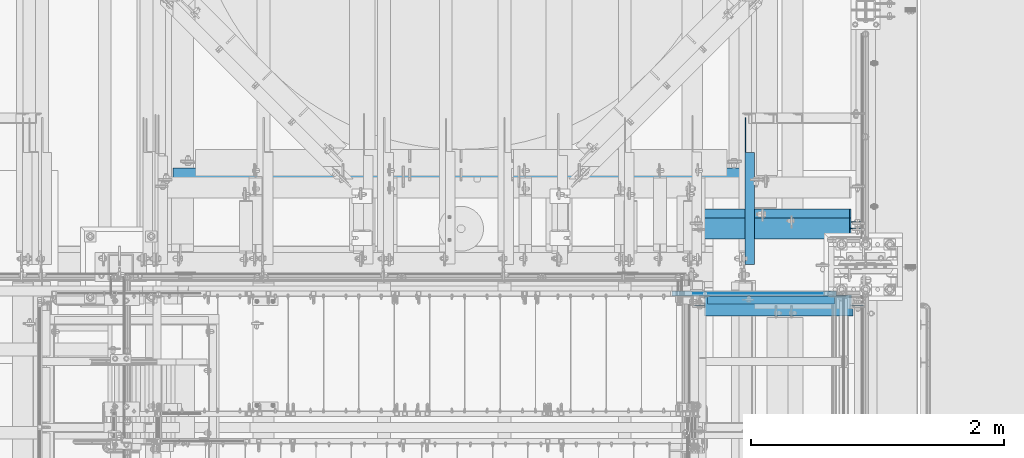
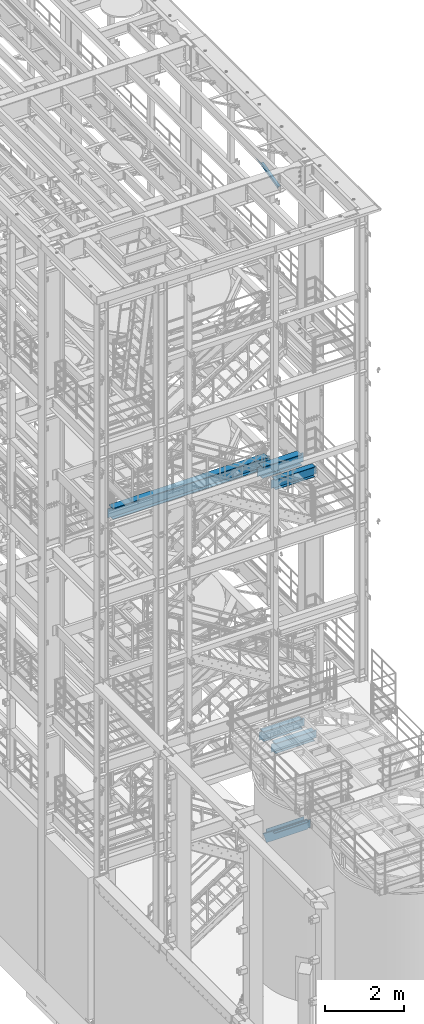
# One storey, part 996 of 1876: 9 beams, 8 elements without a shape of their own.
"""IFC2X3 building model written with IfcOpenShell, lengths in millimetres."""

import ifcopenshell
import ifcopenshell.guid

model = None  # the IFC model being written
_history = None  # IfcOwnerHistory: only IFC2X3 demands one
_inside = {}  # id of a spatial element -> (the spatial element, [elements in it])
_under = {}  # id of a project, library or spatial element -> (it, [spatial elements below it])
_declared = {}  # id of a project -> (the project, [libraries it declares])
_typed = {}  # id of a type object -> (the type object, [elements of that type])
_made_of = {}  # id of a material, layer set ... -> (it, [elements and type objects made of it])


def new_model(schema):
    """Start an empty IFC model of exactly this schema.

    Asked for "IFC4X3", IfcOpenShell would pick the latest addendum, in which some entities
    have other attributes; the version numbers below select the first issue.
    IFC2X3 requires an IfcOwnerHistory on every rooted entity: one is made here for all.
    """
    global model, _history
    if schema == "IFC4X3":
        model = ifcopenshell.file(schema_version=(4, 3, 0, 0))
    else:
        model = ifcopenshell.file(schema=schema)
    _inside.clear()
    _under.clear()
    _declared.clear()
    _typed.clear()
    _made_of.clear()
    _history = None
    if model.schema == "IFC2X3":
        org = make("IfcOrganization", Name="unknown")
        user = make(
            "IfcPersonAndOrganization",
            ThePerson=make("IfcPerson", FamilyName="unknown"),
            TheOrganization=org,
        )
        app = make(
            "IfcApplication",
            ApplicationDeveloper=org,
            Version="unknown",
            ApplicationFullName="unknown",
            ApplicationIdentifier="unknown",
        )
        _history = make(
            "IfcOwnerHistory",
            OwningUser=user,
            OwningApplication=app,
            ChangeAction="ADDED",
            CreationDate=0,
        )
    return model


def make(cls, **values):
    """One entity of the class cls with the attributes given. An attribute that is None is left unset."""
    return model.create_entity(
        cls, **{name: value for name, value in values.items() if value is not None}
    )


def rooted(cls, **values):
    """An entity with a GlobalId (a new one), such as an element, a storey or a relation."""
    return make(cls, GlobalId=ifcopenshell.guid.new(), OwnerHistory=_history, **values)


def si_unit(unit_type, name, prefix=None):
    """IfcSIUnit, for example si_unit("LENGTHUNIT", "METRE", prefix="MILLI")."""
    return make("IfcSIUnit", UnitType=unit_type, Prefix=prefix, Name=name)


def assignment(units):
    """IfcUnitAssignment: the units of a project."""
    return None if units is None else make("IfcUnitAssignment", Units=units)


def point(xyz):
    """IfcCartesianPoint."""
    return None if xyz is None else make("IfcCartesianPoint", Coordinates=xyz)


def direction(xyz):
    """IfcDirection."""
    return None if xyz is None else make("IfcDirection", DirectionRatios=xyz)


def frame(location, z_axis=None, x_axis=None):
    """IfcAxis2Placement3D, a coordinate frame: its origin and axes. An axis left out is left unset."""
    return make(
        "IfcAxis2Placement3D",
        Location=point(location),
        Axis=direction(z_axis),
        RefDirection=direction(x_axis),
    )


def origin_with_axes():
    """The frame at (0, 0, 0) with the z axis (0, 0, 1) and the x axis (1, 0, 0) written out."""
    return frame((0.0, 0.0, 0.0), z_axis=(0.0, 0.0, 1.0), x_axis=(1.0, 0.0, 0.0))


def place(relative_to, where):
    """IfcLocalPlacement: puts the frame where relative to a parent placement (None: the world)."""
    return make(
        "IfcLocalPlacement", PlacementRelTo=relative_to, RelativePlacement=where
    )


def context(
    kind, dimensions, precision=None, world=None, true_north=None, identifier=None
):
    """IfcGeometricRepresentationContext, for example the 3D "Model" context."""
    return make(
        "IfcGeometricRepresentationContext",
        ContextIdentifier=identifier,
        ContextType=kind,
        CoordinateSpaceDimension=dimensions,
        Precision=precision,
        WorldCoordinateSystem=world,
        TrueNorth=true_north,
    )


def subcontext(parent, identifier, kind, view, scale=None):
    """IfcGeometricRepresentationSubContext, for example "Body" below "Model"."""
    return make(
        "IfcGeometricRepresentationSubContext",
        ContextIdentifier=identifier,
        ContextType=kind,
        ParentContext=parent,
        TargetScale=scale,
        TargetView=view,
    )


def project(units=None, contexts=None):
    """IfcProject with its units and contexts."""
    return rooted(
        "IfcProject",
        Name="project",
        RepresentationContexts=contexts,
        UnitsInContext=assignment(units),
    )


def spatial(cls, under=None, at=None, **own):
    """A site, building, storey or space (cls), placed at a placement, below another one or the project."""
    s = rooted(cls, ObjectPlacement=at, **own)
    if under is not None:
        _under.setdefault(under.id(), (under, []))[1].append(s)
    return s


def faces_of(points, faces, orient=None, outer=None):
    """IfcFace entities. A face is a list of loops; a loop is a list of indices into points, from 0.

    orient and outer hold one flag for each loop. By default every Orientation is true, the
    first loop of a face is its IfcFaceOuterBound and the others are IfcFaceBound.
    """
    made = []
    for i, loops in enumerate(faces):
        bounds = []
        for j, loop in enumerate(loops):
            is_outer = j == 0 if outer is None else outer[i][j]
            bounds.append(
                make(
                    "IfcFaceOuterBound" if is_outer else "IfcFaceBound",
                    Bound=make("IfcPolyLoop", Polygon=[points[k] for k in loop]),
                    Orientation=True if orient is None else orient[i][j],
                )
            )
        made.append(make("IfcFace", Bounds=bounds))
    return made


def faceted_brep(points, faces, orient=None, outer=None, voids=None):
    """IfcFacetedBrep: a solid bounded by flat faces; with voids (closed shells), ...WithVoids."""
    shared = [point(p) for p in points]
    hull = make("IfcClosedShell", CfsFaces=faces_of(shared, faces, orient, outer))
    if voids is None:
        return make("IfcFacetedBrep", Outer=hull)
    return make(
        "IfcFacetedBrepWithVoids",
        Outer=hull,
        Voids=[
            make(cls, CfsFaces=faces_of(shared, fs, o, b)) for cls, fs, o, b in voids
        ],
    )


def shape(context_of_items, identifier, shape_type, items):
    """IfcShapeRepresentation: the items that make up one representation, for example the "Body"."""
    return make(
        "IfcShapeRepresentation",
        ContextOfItems=context_of_items,
        RepresentationIdentifier=identifier,
        RepresentationType=shape_type,
        Items=items,
    )


def material(Name=None, Category=None):
    """IfcMaterial."""
    return make("IfcMaterial", Name=Name, Category=Category)


def made_of(thing, what):
    """Note that an element or type object is made of a material, layer set ...; save() writes the relation."""
    if what is not None:
        _made_of.setdefault(what.id(), (what, []))[1].append(thing)
    return thing


def type_object(cls, material=None, **own):
    """A type object (cls), such as IfcWallType, which elements share."""
    return made_of(rooted(cls, **own), material)


def element(
    cls,
    number,
    at=None,
    inside=None,
    cuts=None,
    type_object=None,
    material=None,
    context=None,
    identifier="Body",
    shape_type=None,
    held_by="IfcProductDefinitionShape",
    body=None,
    shapes=None,
    **own,
):
    """One element of the class cls, such as IfcWall. Its Tag is "e" and its number.

    at: its placement. inside: the storey or other place that contains it. cuts: it is an
    opening in that element (IfcRelVoidsElement). A single representation is given by context,
    identifier, shape_type and body (its items); several are given by shapes. held_by: the class
    of the entity that holds the representations. save() writes the other relations.
    """
    e = rooted(cls, Tag="e%d" % number, ObjectPlacement=at, **own)
    if body is not None:
        shapes = [shape(context, identifier, shape_type, body)]
    if shapes is not None:
        e.Representation = make(held_by, Representations=shapes)
    if inside is not None:
        _inside.setdefault(inside.id(), (inside, []))[1].append(e)
    if cuts is not None:
        rooted(
            "IfcRelVoidsElement", RelatingBuildingElement=cuts, RelatedOpeningElement=e
        )
    if type_object is not None:
        _typed.setdefault(type_object.id(), (type_object, []))[1].append(e)
    return made_of(e, material)


def aggregate(whole, parts):
    """IfcRelAggregates: a whole, such as a stair, and the parts it consists of."""
    return rooted("IfcRelAggregates", RelatingObject=whole, RelatedObjects=parts)


def save(model, path):
    """Write the relations noted so far, then the file.

    IfcRelAggregates (storeys below a building ...), IfcRelContainedInSpatialStructure (elements
    in a storey), IfcRelDefinesByType, IfcRelAssociatesMaterial and IfcRelDeclares: one each for
    every whole, place, type object, material and project.
    """
    for whole, parts in _under.values():
        aggregate(whole, parts)
    for where, things in _inside.values():
        rooted(
            "IfcRelContainedInSpatialStructure",
            RelatedElements=things,
            RelatingStructure=where,
        )
    for kind, things in _typed.values():
        rooted("IfcRelDefinesByType", RelatedObjects=things, RelatingType=kind)
    for what, things in _made_of.values():
        rooted("IfcRelAssociatesMaterial", RelatedObjects=things, RelatingMaterial=what)
    for by, libraries in _declared.values():
        rooted("IfcRelDeclares", RelatingContext=by, RelatedDefinitions=libraries)
    model.write(path)


model = new_model("IFC2X3")

# Units and contexts
model_context = context("Model", 3, precision=1e-05, world=origin_with_axes())
body_context = subcontext(model_context, "Body", "Model", "MODEL_VIEW")
ifc_project = project(units=[si_unit("LENGTHUNIT", "METRE", prefix="MILLI"), si_unit("AREAUNIT", "SQUARE_METRE"), si_unit("VOLUMEUNIT", "CUBIC_METRE"), si_unit("MASSUNIT", "GRAM", prefix="KILO"), si_unit("TIMEUNIT", "SECOND"), si_unit("PLANEANGLEUNIT", "RADIAN"), si_unit("SOLIDANGLEUNIT", "STERADIAN"), si_unit("THERMODYNAMICTEMPERATUREUNIT", "DEGREE_CELSIUS"), si_unit("LUMINOUSINTENSITYUNIT", "LUMEN")], contexts=[model_context])

# Site, building, storey
site_placement = place(None, origin_with_axes())
site = spatial("IfcSite", under=ifc_project, at=site_placement, CompositionType="ELEMENT")
building_placement = place(site_placement, origin_with_axes())
building = spatial("IfcBuilding", under=site, at=building_placement, Name="Undefined", CompositionType="ELEMENT")
storey_placement = place(building_placement, origin_with_axes())
storey = spatial("IfcBuildingStorey", under=building, at=storey_placement, Name="Undefined", CompositionType="ELEMENT", Elevation=0.0)

# Assembly, beam
assembly_1_placement = place(storey_placement, origin_with_axes())
assembly_1 = element("IfcElementAssembly", 1, at=assembly_1_placement, inside=storey, Name="STRINGER", AssemblyPlace="NOTDEFINED", PredefinedType="RIGID_FRAME")
ifc_material_1 = material(Name="STEEL/A36")
beam_type_1 = type_object("IfcBeamType", Name="L2-1/2X2-1/2X1/4", PredefinedType="NOTDEFINED")
beam_1_placement = place(assembly_1_placement, frame((6284.91249266997, -4832.34999887347, 2266.27941810345), z_axis=(0.0, -1.0, 0.0), x_axis=(1.0, 0.0, 0.0)))
beam_1 = element("IfcBeam", 2, at=beam_1_placement, type_object=beam_type_1, material=ifc_material_1, Name="ANGLE", ObjectType="L2-1/2X2-1/2X1/4", context=body_context, shape_type="Brep", body=[
    faceted_brep([(82.5500000000022, 19.0499999999556, -25.3999999999996), (82.5500000000022, 19.0499996253002, -31.75), (107.950000724835, 19.0499996252966, -31.75), (107.950000724835, 19.049999999952, -25.3999999999996), (107.950000724835, -31.7499992371049, -25.3999999999996), (107.950000724835, -31.75, -31.75), (82.5500000000022, 25.3999999999996, 31.75), (82.5500000000022, 25.3999999999996, -25.3999999999996), (1090.61250039314, 25.4000000000001, -25.3999999996768), (1090.61250039313, 25.4000000000001, 31.7500000003247), (82.5500000000022, 31.75, 31.75), (1090.61250039313, 31.75, 31.7500000003247), (82.5500000000022, 31.75, -31.75), (1090.61250039314, 31.75, -31.7499999996771), (1090.61250039314, -31.75, -25.3999999996768), (1090.61250039314, -31.75, -31.7499999996771)], [[[0, 1, 2, 3]], [[4, 3, 2, 5]], [[6, 7, 8, 9]], [[10, 6, 9, 11]], [[12, 10, 11, 13]], [[9, 8, 14, 15, 13, 11]], [[15, 14, 4, 5]], [[1, 12, 13, 15, 5, 2]], [[7, 6, 10, 12, 1, 0]], [[14, 8, 7, 0, 3, 4]]]),
])

assembly_2_placement = place(storey_placement, origin_with_axes())
assembly_2 = element("IfcElementAssembly", 3, at=assembly_2_placement, inside=storey, Name="RAIL", AssemblyPlace="NOTDEFINED", PredefinedType="RIGID_FRAME")
beam_type_2 = type_object("IfcBeamType", PredefinedType="NOTDEFINED")
beam_2_placement = place(assembly_2_placement, frame((6185.29687392229, -4781.55000191054, 2393.1836258416), z_axis=(0.0, 0.0, 1.0), x_axis=(1.0, 0.0, 0.0)))
beam_2 = element("IfcBeam", 4, at=beam_2_placement, type_object=beam_type_2, material=ifc_material_1, Name="PLATE", context=body_context, shape_type="Brep", body=[
    faceted_brep([(0.0, 3.17500000000018, -50.8000000000002), (0.0, 3.17500000000018, 50.8000000000002), (1102.91562696768, 3.17500000000018, 50.8000000000466), (1102.91562696769, 3.17500000000018, -50.7999999999533), (0.0, -3.17500000000018, 50.8000000000002), (1102.91562696768, -3.17500000000018, 50.8000000000466), (0.0, -3.17500000000018, -50.8000000000002), (1102.91562696769, -3.17500000000018, -50.7999999999533)], [[[0, 1, 2, 3]], [[1, 4, 5, 2]], [[4, 6, 7, 5]], [[6, 0, 3, 7]], [[5, 7, 3, 2]], [[6, 4, 1, 0]]]),
])
aggregate(assembly_2, [beam_2])

assembly_3_placement = place(storey_placement, origin_with_axes())
assembly_3 = element("IfcElementAssembly", 5, at=assembly_3_placement, inside=storey, AssemblyPlace="NOTDEFINED", PredefinedType="RIGID_FRAME")
beam_type_3 = type_object("IfcBeamType", Name="L3X3X3/8", PredefinedType="NOTDEFINED")
beam_3_placement = place(assembly_3_placement, frame((6702.42500019074, -4562.78281844778, 21997.5317219592), z_axis=(1.0, 0.0, 0.0), x_axis=(0.0, 0.97029600569138, 0.241920774923019)))
beam_3 = element("IfcBeam", 6, at=beam_3_placement, type_object=beam_type_3, material=ifc_material_1, ObjectType="L3X3X3/8", context=body_context, shape_type="Brep", body=[
    faceted_brep([(20.4512332895073, 38.1000000000495, -38.0999999999999), (20.4512332895073, 38.1000000000495, 38.0999999999999), (892.440924395522, 38.0999999997366, 38.0999999999999), (892.440924395522, 38.0999999997366, -38.0999999999999), (20.4512332895037, 28.5750000000371, 38.0999999999999), (930.643800759319, 28.5749999997061, 38.0999999999999), (20.4512332895037, 28.5750000000371, -28.575), (930.643800759319, 28.5749999997061, -28.575), (20.4512332894728, -38.1000000000604, -28.575), (1198.0639353059, -38.1000000004824, -28.575), (20.4512332894728, -38.1000000000604, -38.0999999999999), (1198.0639353059, -38.1000000004824, -38.0999999999999)], [[[0, 1, 2, 3]], [[1, 4, 5, 2]], [[4, 6, 7, 5]], [[6, 8, 9, 7]], [[8, 10, 11, 9]], [[10, 0, 3, 11]], [[5, 7, 9, 11, 3, 2]], [[10, 8, 6, 4, 1, 0]]]),
])
aggregate(assembly_3, [beam_3])

# Beam
beam_type_4 = type_object("IfcBeamType", Name="MC12X10.6", PredefinedType="NOTDEFINED")
beam_4_placement = place(assembly_1_placement, frame((7485.06250068596, -4781.55000121439, 2177.28362013292), z_axis=(0.0, 0.0, 1.0), x_axis=(-1.0, 0.0, 0.0)))
beam_4 = element("IfcBeam", 7, at=beam_4_placement, type_object=beam_type_4, material=ifc_material_1, Name="STRINGER", ObjectType="MC12X10.6", context=body_context, shape_type="Brep", body=[
    faceted_brep([(20.6375006859598, 14.2875000000004, -127.0), (20.6375006859598, 19.0500000000002, -127.0), (84.1375008766954, 19.0500000000002, -127.0), (84.1375008766954, 14.2875000000004, -127.0), (88.9975803947409, 19.0500000000002, -127.966729922588), (88.9975803947409, 14.2875000000004, -127.966729922588), (93.1177568628946, 19.0500000000002, -130.719743823066), (93.1177568628946, 14.2875000000004, -130.719743823066), (95.870770763373, 19.0500000000002, -134.83992029122), (95.870770763373, 14.2875000000004, -134.83992029122), (96.8375006859605, 14.2875000000004, -139.699999809265), (96.8375006859605, 19.0500000000002, -139.699999809265), (96.8375006859605, 19.0500000000002, -152.4), (96.8375006859605, -19.0500000000002, -152.4), (96.8375006859605, -19.0500000000002, -144.841595), (96.8375006859605, 14.2875000000004, -144.17817875), (1394.24448031702, -19.0500000000002, 144.841595), (1396.43977205058, -19.0500000000002, 152.4), (96.8375006859605, -19.0500000000002, 152.4), (96.8375006859605, -19.0500000000002, 144.841595), (1396.43977205058, 19.0500000000002, 152.4), (96.8375006859605, 19.0500000000002, 152.4), (84.1375008766954, 14.2875000000004, 127.0), (84.1375008766954, 19.0500000000002, 127.0), (20.6375006859598, 19.0500000000002, 127.0), (20.6375006859598, 14.2875000000004, 127.0), (88.9975803947409, 14.2875000000004, 127.966729922588), (88.9975803947409, 19.0500000000002, 127.966729922588), (93.1177568628946, 14.2875000000004, 130.719743823066), (93.1177568628946, 19.0500000000002, 130.719743823066), (95.870770763373, 14.2875000000004, 134.83992029122), (95.870770763373, 19.0500000000002, 134.83992029122), (96.8375006859605, 14.2875000000004, 139.699999809265), (96.8375006859605, 19.0500000000002, 139.699999809265), (96.8375006859605, 14.2875000000004, 144.17817875), (1394.05179519237, 14.2875000000004, 144.17817875), (1310.30048417633, 14.2875000000004, -144.17817875), (1310.10779905169, -19.0500000000002, -144.841595), (1307.91250731813, -19.0500000000002, -152.4), (1307.91250731813, 19.0500000000002, -152.4)], [[[0, 1, 2, 3]], [[3, 2, 4, 5]], [[5, 4, 6, 7]], [[7, 6, 8, 9]], [[10, 11, 12, 13, 14, 15]], [[9, 8, 11, 10]], [[16, 17, 18, 19]], [[17, 20, 21, 18]], [[22, 23, 24, 25]], [[26, 27, 23, 22]], [[28, 29, 27, 26]], [[30, 31, 29, 28]], [[32, 33, 31, 30]], [[18, 21, 33, 32, 34, 19]], [[35, 16, 19, 34]], [[17, 16, 35, 36, 37, 38, 39, 20]], [[37, 36, 15, 14]], [[38, 37, 14, 13]], [[39, 38, 13, 12]], [[6, 4, 2, 1, 24, 23, 27, 29, 31, 33, 21, 20, 39, 12, 11, 8]], [[25, 24, 1, 0]], [[36, 35, 34, 32, 30, 28, 26, 22, 25, 0, 3, 5, 7, 9, 10, 15]]]),
])

aggregate(assembly_1, [beam_4, beam_1])

# Assembly, beam
assembly_4_placement = place(storey_placement, origin_with_axes())
assembly_4 = element("IfcElementAssembly", 8, at=assembly_4_placement, inside=storey, Name="BEAM", AssemblyPlace="NOTDEFINED", PredefinedType="RIGID_FRAME")
ifc_material_2 = material(Name="STEEL/A992")
beam_type_5 = type_object("IfcBeamType", Name="W12X30", PredefinedType="NOTDEFINED")
beam_5_placement = place(assembly_4_placement, frame((6233.31875, -4876.403125, 13152.4375), z_axis=(0.0, 0.0, 1.0), x_axis=(1.0, 0.0, 0.0)))
beam_5 = element("IfcBeam", 9, at=beam_5_placement, type_object=beam_type_5, material=ifc_material_2, Name="BEAM", ObjectType="W12X30", context=body_context, shape_type="Brep", body=[
    faceted_brep([(1273.96875, -3.17500000000018, -146.049999999999), (1273.96875, -82.5500000000002, -146.049999999999), (1273.96875, -82.5500000000002, -157.1625), (1273.96875, 82.5500000000002, -157.1625), (1273.96875, 82.5500000000002, -146.049999999999), (1273.96875, 3.17500000000018, -146.049999999999), (1273.96875, 3.17500000000018, -138.112499809266), (1273.96875, -3.17500000000018, -138.112499809266), (1274.93547992258, 3.17500000000018, -133.252420291219), (1274.93547992258, -3.17500000000018, -133.252420291219), (1277.68849382306, 3.17500000000018, -129.132243823065), (1277.68849382306, -3.17500000000018, -129.132243823065), (1281.80867029122, 3.17500000000018, -126.379229922588), (1281.80867029122, -3.17500000000018, -126.379229922588), (1286.66874980926, 3.17500000000018, -125.4125), (1286.66874980926, -3.17500000000018, -125.4125), (1369.21875, -3.17500000000018, -125.4125), (1369.21875, 3.17500000000018, -125.4125), (113.506249999999, 3.17500000000018, 146.049999999999), (113.506249999999, 82.5500000000002, 146.049999999999), (1286.66875, 82.5500000000002, 146.049999999999), (1286.66875, 3.17500000000018, 146.049999999999), (126.206249999999, -3.17500000000018, -144.462499809266), (126.206249999999, 3.17500000000018, -144.462499809266), (126.206249999999, 3.17500000000018, -146.049999999999), (126.206249999999, 82.5500000000002, -146.049999999999), (126.206249999999, 82.5500000000002, -157.1625), (126.206249999999, -82.5500000000002, -157.1625), (126.206249999999, -82.5500000000002, -146.049999999999), (126.206249999999, -3.17500000000018, -146.049999999999), (125.239520077412, -3.17500000000018, -139.602420291219), (125.239520077412, 3.17500000000018, -139.602420291219), (122.486506176933, -3.17500000000018, -135.482243823066), (122.486506176933, 3.17500000000018, -135.482243823066), (118.36632970878, -3.17500000000018, -132.729229922588), (118.36632970878, 3.17500000000018, -132.729229922588), (113.506250190734, -3.17500000000018, -131.762500000001), (113.506250190734, 3.17500000000018, -131.762500000001), (30.9562499999993, -3.17500000000018, -131.762500000001), (30.9562499999993, 3.17500000000018, -131.762500000001), (30.9562499999993, -3.17500000000018, 131.762500000001), (30.9562499999993, 3.17500000000018, 131.762500000001), (100.806250190734, -3.17500000000018, 131.762500000001), (100.806250190734, 3.17500000000018, 131.762500000001), (105.66632970878, -3.17500000000018, 132.729229922588), (105.66632970878, 3.17500000000018, 132.729229922588), (109.786506176933, -3.17500000000018, 135.482243823066), (109.786506176933, 3.17500000000018, 135.482243823066), (112.539520077412, -3.17500000000018, 139.602420291219), (112.539520077412, 3.17500000000018, 139.602420291219), (113.506249999999, -3.17500000000018, 144.462499809266), (113.506249999999, 3.17500000000018, 144.462499809266), (113.506249999999, -82.5500000000002, 157.1625), (113.506249999999, 82.5500000000002, 157.1625), (113.506249999999, -3.17500000000018, 146.049999999999), (113.506249999999, -82.5500000000002, 146.049999999999), (1286.66875, -3.17500000000018, 146.049999999999), (1286.66875, -82.5500000000002, 146.049999999999), (1286.66875, -82.5500000000002, 157.1625), (1286.66875, 82.5500000000002, 157.1625), (1286.66875, -3.17500000000018, 138.112499809266), (1286.66875, 3.17500000000018, 138.112499809266), (1287.63547992258, -3.17500000000018, 133.252420291219), (1287.63547992258, 3.17500000000018, 133.252420291219), (1290.38849382306, -3.17500000000018, 129.132243823065), (1290.38849382306, 3.17500000000018, 129.132243823065), (1294.50867029122, -3.17500000000018, 126.379229922588), (1294.50867029122, 3.17500000000018, 126.379229922588), (1299.36874980926, -3.17500000000018, 125.4125), (1299.36874980926, 3.17500000000018, 125.4125), (1369.21875, -3.17500000000018, 125.4125), (1369.21875, 3.17500000000018, 125.4125)], [[[0, 1, 2, 3, 4, 5, 6, 7]], [[7, 6, 8, 9]], [[9, 8, 10, 11]], [[11, 10, 12, 13]], [[13, 12, 14, 15]], [[16, 15, 14, 17]], [[18, 19, 20, 21]], [[22, 23, 24, 25, 26, 27, 28, 29]], [[30, 31, 23, 22]], [[32, 33, 31, 30]], [[34, 35, 33, 32]], [[36, 37, 35, 34]], [[38, 39, 37, 36]], [[40, 41, 39, 38]], [[42, 43, 41, 40]], [[44, 45, 43, 42]], [[46, 47, 45, 44]], [[48, 49, 47, 46]], [[50, 51, 49, 48]], [[52, 53, 19, 18, 51, 50, 54, 55]], [[55, 54, 56, 57]], [[52, 55, 57, 58]], [[53, 52, 58, 59]], [[19, 53, 59, 20]], [[58, 57, 56, 60, 61, 21, 20, 59]], [[62, 63, 61, 60]], [[64, 65, 63, 62]], [[66, 67, 65, 64]], [[68, 69, 67, 66]], [[70, 71, 69, 68]], [[71, 70, 16, 17]], [[12, 10, 8, 6, 5, 24, 23, 31, 33, 35, 37, 39, 41, 43, 45, 47, 49, 51, 18, 21, 61, 63, 65, 67, 69, 71, 17, 14]], [[25, 24, 5, 4]], [[26, 25, 4, 3]], [[27, 26, 3, 2]], [[28, 27, 2, 1]], [[29, 28, 1, 0]], [[70, 68, 66, 64, 62, 60, 56, 54, 50, 48, 46, 44, 42, 40, 38, 36, 34, 32, 30, 22, 29, 0, 7, 9, 11, 13, 15, 16]]]),
])
aggregate(assembly_4, [beam_5])

assembly_5_placement = place(storey_placement, origin_with_axes())
assembly_5 = element("IfcElementAssembly", 10, at=assembly_5_placement, inside=storey, Name="BEAM", AssemblyPlace="NOTDEFINED", PredefinedType="RIGID_FRAME")
beam_6_placement = place(assembly_5_placement, frame((6248.4, -4876.8, 4973.6375), z_axis=(0.0, 0.0, 1.0), x_axis=(1.0, 0.0, 0.0)))
beam_6 = element("IfcBeam", 11, at=beam_6_placement, type_object=beam_type_5, material=ifc_material_2, Name="BEAM", ObjectType="W12X30", context=body_context, shape_type="Brep", body=[
    faceted_brep([(15.875, -3.17500000000018, -131.762499999999), (15.875, 3.17500000000018, -131.762499999999), (98.4250001907349, 3.17500000000018, -131.762499999999), (98.4250001907349, -3.17500000000018, -131.762499999999), (103.28507970878, 3.17500000000018, -132.729229922586), (103.28507970878, -3.17500000000018, -132.729229922586), (107.405256176934, 3.17500000000018, -135.482243823065), (107.405256176934, -3.17500000000018, -135.482243823065), (110.158270077412, 3.17500000000018, -139.602420291219), (110.158270077412, -3.17500000000018, -139.602420291219), (111.125, -3.17500000000018, -144.462499809264), (111.125, 3.17500000000018, -144.462499809264), (111.124999999998, 3.17500000000018, -146.049999999999), (111.125, 82.5500000000002, -146.05), (111.125, 82.5500000000002, -157.1625), (111.125, -82.5500000000002, -157.1625), (111.125, -82.5500000000002, -146.05), (111.124999999998, -3.17500000000018, -146.049999999999), (1246.1875, 82.5500000000002, 146.05), (1246.1875, 3.17500000000018, 146.05), (95.2499999999982, 3.17500000000018, 146.049999999999), (95.25, 82.5500000000002, 146.05), (82.5500001907349, -3.17500000000018, 131.762500000001), (82.5500001907349, 3.17500000000018, 131.762500000001), (15.875, 3.17500000000018, 131.762500000001), (15.875, -3.17500000000018, 131.762500000001), (87.4100797087804, -3.17500000000018, 132.729229922588), (87.4100797087804, 3.17500000000018, 132.729229922588), (91.530256176934, -3.17500000000018, 135.482243823067), (91.530256176934, 3.17500000000018, 135.482243823067), (94.2832700774125, -3.17500000000018, 139.60242029122), (94.2832700774125, 3.17500000000018, 139.60242029122), (95.25, -3.17500000000018, 144.462499809266), (95.25, 3.17500000000018, 144.462499809266), (1246.1875, -82.5500000000002, 157.1625), (1246.1875, 82.5500000000002, 157.1625), (95.25, 82.5500000000002, 157.1625), (95.25, -82.5500000000002, 157.1625), (1246.1875, -82.5500000000002, 146.05), (95.25, -82.5500000000002, 146.05), (1246.1875, -3.17500000000018, 146.05), (95.2499999999982, -3.17500000000018, 146.049999999999), (1246.1875, -3.17500000000018, 131.762499809266), (1246.1875, 3.17500000000018, 131.762499809266), (1247.15422992259, -3.17500000000018, 126.902420291221), (1247.15422992259, 3.17500000000018, 126.902420291221), (1249.90724382307, -3.17500000000018, 122.782243823067), (1249.90724382307, 3.17500000000018, 122.782243823067), (1254.02742029122, -3.17500000000018, 120.029229922588), (1254.02742029122, 3.17500000000018, 120.029229922588), (1258.88749980927, -3.17500000000018, 119.062500000001), (1258.88749980927, 3.17500000000018, 119.062500000001), (1354.1375, -3.17500000000018, 119.062500000001), (1354.1375, 3.17500000000018, 119.062500000001), (1354.1375, -3.17500000000018, -131.762499999999), (1354.1375, 3.17500000000018, -131.762499999999), (1271.58749980926, -3.17500000000018, -131.762499999999), (1271.58749980926, 3.17500000000018, -131.762499999999), (1266.72742029122, -3.17500000000018, -132.729229922586), (1266.72742029122, 3.17500000000018, -132.729229922586), (1262.60724382307, -3.17500000000018, -135.482243823065), (1262.60724382307, 3.17500000000018, -135.482243823065), (1259.85422992259, -3.17500000000018, -139.602420291219), (1259.85422992259, 3.17500000000018, -139.602420291219), (1258.8875, -3.17500000000018, -144.462499809264), (1258.8875, 3.17500000000018, -144.462499809264), (1258.8875, -3.17500000000018, -146.05), (1258.8875, -82.5500000000002, -146.05), (1258.8875, -82.5500000000002, -157.1625), (1258.8875, 82.5500000000002, -157.1625), (1258.8875, 82.5500000000002, -146.05), (1258.8875, 3.17500000000018, -146.05)], [[[0, 1, 2, 3]], [[3, 2, 4, 5]], [[5, 4, 6, 7]], [[7, 6, 8, 9]], [[10, 11, 12, 13, 14, 15, 16, 17]], [[9, 8, 11, 10]], [[18, 19, 20, 21]], [[22, 23, 24, 25]], [[26, 27, 23, 22]], [[28, 29, 27, 26]], [[30, 31, 29, 28]], [[32, 33, 31, 30]], [[34, 35, 36, 37]], [[38, 34, 37, 39]], [[40, 38, 39, 41]], [[37, 36, 21, 20, 33, 32, 41, 39]], [[35, 18, 21, 36]], [[34, 38, 40, 42, 43, 19, 18, 35]], [[44, 45, 43, 42]], [[46, 47, 45, 44]], [[48, 49, 47, 46]], [[50, 51, 49, 48]], [[52, 53, 51, 50]], [[53, 52, 54, 55]], [[54, 56, 57, 55]], [[58, 59, 57, 56]], [[60, 61, 59, 58]], [[62, 63, 61, 60]], [[64, 65, 63, 62]], [[66, 67, 68, 69, 70, 71, 65, 64]], [[67, 66, 17, 16]], [[68, 67, 16, 15]], [[69, 68, 15, 14]], [[70, 69, 14, 13]], [[71, 70, 13, 12]], [[6, 4, 2, 1, 24, 23, 27, 29, 31, 33, 20, 19, 43, 45, 47, 49, 51, 53, 55, 57, 59, 61, 63, 65, 71, 12, 11, 8]], [[25, 24, 1, 0]], [[66, 64, 62, 60, 58, 56, 54, 52, 50, 48, 46, 44, 42, 40, 41, 32, 30, 28, 26, 22, 25, 0, 3, 5, 7, 9, 10, 17]]]),
])
aggregate(assembly_5, [beam_6])

assembly_6_placement = place(storey_placement, origin_with_axes())
assembly_6 = element("IfcElementAssembly", 12, at=assembly_6_placement, inside=storey, Name="BEAM", AssemblyPlace="NOTDEFINED", PredefinedType="RIGID_FRAME")
beam_7_placement = place(assembly_6_placement, frame((6248.4, -4267.2, 4973.6375), z_axis=(0.0, 0.0, 1.0), x_axis=(1.0, 0.0, 0.0)))
beam_7 = element("IfcBeam", 13, at=beam_7_placement, type_object=beam_type_5, material=ifc_material_2, Name="BEAM", ObjectType="W12X30", context=body_context, shape_type="Brep", body=[
    faceted_brep([(1256.50625, -3.17500000000018, -146.05), (1256.50625, -82.5500000000002, -146.05), (1256.50625, -82.5500000000002, -157.1625), (1256.50625, 82.5500000000002, -157.1625), (1256.50625, 82.5500000000002, -146.05), (1256.50625, 3.17500000000018, -146.05), (1256.50625, 3.17500000000018, -144.462499809266), (1256.50625, -3.17500000000018, -144.462499809266), (1257.47297992259, 3.17500000000018, -139.60242029122), (1257.47297992259, -3.17500000000018, -139.60242029122), (1260.22599382307, 3.17500000000018, -135.482243823067), (1260.22599382307, -3.17500000000018, -135.482243823067), (1264.34617029122, 3.17500000000018, -132.729229922588), (1264.34617029122, -3.17500000000018, -132.729229922588), (1269.20624980926, 3.17500000000018, -131.762500000001), (1269.20624980926, -3.17500000000018, -131.762500000001), (1351.75625, -3.17500000000018, -131.762500000001), (1351.75625, 3.17500000000018, -131.762500000001), (95.2499999999982, 3.17500000000018, 146.049999999999), (95.25, 82.5500000000002, 146.05), (1243.80625, 82.5500000000002, 146.05), (1243.80625, 3.17500000000018, 146.05), (111.125, -3.17500000000018, -144.462499809264), (111.125, 3.17500000000018, -144.462499809264), (111.124999999998, 3.17500000000018, -146.049999999999), (111.125, 82.5500000000002, -146.05), (111.125, 82.5500000000002, -157.1625), (111.125, -82.5500000000002, -157.1625), (111.125, -82.5500000000002, -146.05), (111.124999999998, -3.17500000000018, -146.049999999999), (110.158270077412, -3.17500000000018, -139.602420291219), (110.158270077412, 3.17500000000018, -139.602420291219), (107.405256176934, -3.17500000000018, -135.482243823065), (107.405256176934, 3.17500000000018, -135.482243823065), (103.28507970878, -3.17500000000018, -132.729229922586), (103.28507970878, 3.17500000000018, -132.729229922586), (98.4250001907349, -3.17500000000018, -131.762499999999), (98.4250001907349, 3.17500000000018, -131.762499999999), (15.875, -3.17500000000018, -131.762499999999), (15.875, 3.17500000000018, -131.762499999999), (15.875, -3.17500000000018, 131.762500000001), (15.875, 3.17500000000018, 131.762500000001), (82.5500001907349, -3.17500000000018, 131.762500000001), (82.5500001907349, 3.17500000000018, 131.762500000001), (87.4100797087804, -3.17500000000018, 132.729229922588), (87.4100797087804, 3.17500000000018, 132.729229922588), (91.530256176934, -3.17500000000018, 135.482243823067), (91.530256176934, 3.17500000000018, 135.482243823067), (94.2832700774125, -3.17500000000018, 139.60242029122), (94.2832700774125, 3.17500000000018, 139.60242029122), (95.25, -3.17500000000018, 144.462499809266), (95.25, 3.17500000000018, 144.462499809266), (95.25, -82.5500000000002, 157.1625), (95.25, 82.5500000000002, 157.1625), (95.2499999999982, -3.17500000000018, 146.049999999999), (95.25, -82.5500000000002, 146.05), (1243.80625, -3.17500000000018, 146.05), (1243.80625, -82.5500000000002, 146.05), (1243.80625, -82.5500000000002, 157.1625), (1243.80625, 82.5500000000002, 157.1625), (1243.80625, -3.17500000000018, 131.762499809264), (1243.80625, 3.17500000000018, 131.762499809264), (1244.77297992259, -3.17500000000018, 126.902420291219), (1244.77297992259, 3.17500000000018, 126.902420291219), (1247.52599382307, -3.17500000000018, 122.782243823065), (1247.52599382307, 3.17500000000018, 122.782243823065), (1251.64617029122, -3.17500000000018, 120.029229922587), (1251.64617029122, 3.17500000000018, 120.029229922587), (1256.50624980926, -3.17500000000018, 119.062499999999), (1256.50624980926, 3.17500000000018, 119.062499999999), (1351.75625, -3.17500000000018, 119.062499999999), (1351.75625, 3.17500000000018, 119.062499999999)], [[[0, 1, 2, 3, 4, 5, 6, 7]], [[7, 6, 8, 9]], [[9, 8, 10, 11]], [[11, 10, 12, 13]], [[13, 12, 14, 15]], [[16, 15, 14, 17]], [[18, 19, 20, 21]], [[22, 23, 24, 25, 26, 27, 28, 29]], [[30, 31, 23, 22]], [[32, 33, 31, 30]], [[34, 35, 33, 32]], [[36, 37, 35, 34]], [[38, 39, 37, 36]], [[40, 41, 39, 38]], [[42, 43, 41, 40]], [[44, 45, 43, 42]], [[46, 47, 45, 44]], [[48, 49, 47, 46]], [[50, 51, 49, 48]], [[52, 53, 19, 18, 51, 50, 54, 55]], [[55, 54, 56, 57]], [[52, 55, 57, 58]], [[53, 52, 58, 59]], [[19, 53, 59, 20]], [[58, 57, 56, 60, 61, 21, 20, 59]], [[62, 63, 61, 60]], [[64, 65, 63, 62]], [[66, 67, 65, 64]], [[68, 69, 67, 66]], [[70, 71, 69, 68]], [[71, 70, 16, 17]], [[12, 10, 8, 6, 5, 24, 23, 31, 33, 35, 37, 39, 41, 43, 45, 47, 49, 51, 18, 21, 61, 63, 65, 67, 69, 71, 17, 14]], [[25, 24, 5, 4]], [[26, 25, 4, 3]], [[27, 26, 3, 2]], [[28, 27, 2, 1]], [[29, 28, 1, 0]], [[70, 68, 66, 64, 62, 60, 56, 54, 50, 48, 46, 44, 42, 40, 38, 36, 34, 32, 30, 22, 29, 0, 7, 9, 11, 13, 15, 16]]]),
])
aggregate(assembly_6, [beam_7])

assembly_7_placement = place(storey_placement, origin_with_axes())
assembly_7 = element("IfcElementAssembly", 14, at=assembly_7_placement, inside=storey, Name="BEAM", AssemblyPlace="NOTDEFINED", PredefinedType="RIGID_FRAME")
beam_type_6 = type_object("IfcBeamType", Name="W14X48", PredefinedType="NOTDEFINED")
beam_8_placement = place(assembly_7_placement, frame((6233.31875, -4216.003125, 13134.975), z_axis=(0.0, 0.0, 1.0), x_axis=(1.0, 0.0, 0.0)))
beam_8 = element("IfcBeam", 15, at=beam_8_placement, type_object=beam_type_6, material=ifc_material_2, Name="BEAM", ObjectType="W14X48", context=body_context, shape_type="Brep", body=[
    faceted_brep([(1271.5875, -3.96875, -158.75), (1271.5875, -101.6, -158.75), (1271.5875, -101.6, -174.625), (1271.5875, 101.6, -174.625), (1271.5875, 101.6, -158.75), (1271.5875, 3.96875, -158.75), (1271.5875, 3.96875, -155.574999809265), (1271.5875, -3.96875, -155.574999809265), (1272.55422992259, 3.96875, -150.714920291219), (1272.55422992259, -3.96875, -150.714920291219), (1275.30724382307, 3.96875, -146.594743823065), (1275.30724382307, -3.96875, -146.594743823065), (1279.42742029122, 3.96875, -143.841729922588), (1279.42742029122, -3.96875, -143.841729922588), (1284.28749980926, 3.96875, -142.875), (1284.28749980926, -3.96875, -142.875), (1366.8375, -3.96875, -142.875), (1366.8375, 3.96875, -142.875), (111.125000000001, 3.96875, 158.75), (111.125000000001, 101.6, 158.75), (1258.8875, 101.6, 158.75), (1258.8875, 3.96875, 158.75), (107.950000000001, -3.96875, -155.574999809265), (107.950000000001, 3.96875, -155.574999809265), (107.950000000001, 3.96875, -158.75), (107.950000000001, 101.6, -158.75), (107.950000000001, 101.6, -174.625), (107.950000000001, -101.6, -174.625), (107.950000000001, -101.6, -158.75), (107.950000000001, -3.96875, -158.75), (106.983270077413, -3.96875, -150.714920291219), (106.983270077413, 3.96875, -150.714920291219), (104.230256176935, -3.96875, -146.594743823065), (104.230256176935, 3.96875, -146.594743823065), (100.110079708781, -3.96875, -143.841729922588), (100.110079708781, 3.96875, -143.841729922588), (95.2500001907356, -3.96875, -142.875), (95.2500001907356, 3.96875, -142.875), (12.6999999999998, -3.96875, -142.875), (12.6999999999998, 3.96875, -142.875), (12.6999999999998, -3.96875, 142.875), (12.6999999999998, 3.96875, 142.875), (98.4250001907358, -3.96875, 142.875), (98.4250001907358, 3.96875, 142.875), (103.285079708781, -3.96875, 143.841729922588), (103.285079708781, 3.96875, 143.841729922588), (107.405256176935, -3.96875, 146.594743823065), (107.405256176935, 3.96875, 146.594743823065), (110.158270077413, -3.96875, 150.714920291219), (110.158270077413, 3.96875, 150.714920291219), (111.125000000001, -3.96875, 155.574999809265), (111.125000000001, 3.96875, 155.574999809265), (111.125000000001, -101.6, 174.625), (111.125000000001, 101.6, 174.625), (111.125000000001, -3.96875, 158.75), (111.125000000001, -101.6, 158.75), (1258.8875, -3.96875, 158.75), (1258.8875, -101.6, 158.75), (1258.8875, -101.6, 174.625), (1258.8875, 101.6, 174.625), (1258.8875, -3.96875, 155.574999809265), (1258.8875, 3.96875, 155.574999809265), (1259.85422992259, -3.96875, 150.714920291219), (1259.85422992259, 3.96875, 150.714920291219), (1262.60724382307, -3.96875, 146.594743823065), (1262.60724382307, 3.96875, 146.594743823065), (1266.72742029122, -3.96875, 143.841729922588), (1266.72742029122, 3.96875, 143.841729922588), (1271.58749980926, -3.96875, 142.875), (1271.58749980926, 3.96875, 142.875), (1366.8375, -3.96875, 142.875), (1366.8375, 3.96875, 142.875)], [[[0, 1, 2, 3, 4, 5, 6, 7]], [[7, 6, 8, 9]], [[9, 8, 10, 11]], [[11, 10, 12, 13]], [[13, 12, 14, 15]], [[16, 15, 14, 17]], [[18, 19, 20, 21]], [[22, 23, 24, 25, 26, 27, 28, 29]], [[30, 31, 23, 22]], [[32, 33, 31, 30]], [[34, 35, 33, 32]], [[36, 37, 35, 34]], [[38, 39, 37, 36]], [[40, 41, 39, 38]], [[42, 43, 41, 40]], [[44, 45, 43, 42]], [[46, 47, 45, 44]], [[48, 49, 47, 46]], [[50, 51, 49, 48]], [[52, 53, 19, 18, 51, 50, 54, 55]], [[55, 54, 56, 57]], [[52, 55, 57, 58]], [[53, 52, 58, 59]], [[19, 53, 59, 20]], [[58, 57, 56, 60, 61, 21, 20, 59]], [[62, 63, 61, 60]], [[64, 65, 63, 62]], [[66, 67, 65, 64]], [[68, 69, 67, 66]], [[70, 71, 69, 68]], [[71, 70, 16, 17]], [[12, 10, 8, 6, 5, 24, 23, 31, 33, 35, 37, 39, 41, 43, 45, 47, 49, 51, 18, 21, 61, 63, 65, 67, 69, 71, 17, 14]], [[25, 24, 5, 4]], [[26, 25, 4, 3]], [[27, 26, 3, 2]], [[28, 27, 2, 1]], [[29, 28, 1, 0]], [[70, 68, 66, 64, 62, 60, 56, 54, 50, 48, 46, 44, 42, 40, 38, 36, 34, 32, 30, 22, 29, 0, 7, 9, 11, 13, 15, 16]]]),
])
aggregate(assembly_7, [beam_8])

assembly_8_placement = place(storey_placement, origin_with_axes())
assembly_8 = element("IfcElementAssembly", 16, at=assembly_8_placement, inside=storey, Name="BEAM", AssemblyPlace="NOTDEFINED", PredefinedType="RIGID_FRAME")
beam_9_placement = place(assembly_8_placement, frame((1930.3998595601, -3892.55, 13134.975), z_axis=(0.0, 0.0, 1.0), x_axis=(1.0, 0.0, 0.0)))
beam_9 = element("IfcBeam", 17, at=beam_9_placement, type_object=beam_type_6, material=ifc_material_2, Name="BEAM", ObjectType="W14X48", context=body_context, shape_type="Brep", body=[
    faceted_brep([(4764.8813904399, -3.96875, -158.75), (4764.8813904399, -101.6, -158.75), (4764.8813904399, -101.6, -174.625), (4764.8813904399, 101.6, -174.625), (4764.8813904399, 101.6, -158.75), (4764.8813904399, 3.96875, -158.75), (4764.8813904399, 3.96875, -155.574999809265), (4764.8813904399, -3.96875, -155.574999809265), (4765.84812036248, 3.96875, -150.714920291219), (4765.84812036248, -3.96875, -150.714920291219), (4768.60113426296, 3.96875, -146.594743823065), (4768.60113426296, -3.96875, -146.594743823065), (4772.72131073112, 3.96875, -143.841729922588), (4772.72131073112, -3.96875, -143.841729922588), (4777.58139024916, 3.96875, -142.875), (4777.58139024916, -3.96875, -142.875), (4866.48139043989, -3.96875, -142.875), (4866.48139043989, 3.96875, -142.875), (210.34417131969, 3.96875, 158.75), (210.34417131969, 101.6, 158.75), (4768.0563904399, 101.6, 158.75), (4768.0563904399, 3.96875, 158.75), (213.519171319689, -3.96875, -155.574999809265), (213.519171319689, 3.96875, -155.574999809265), (213.519171319689, 3.96875, -158.75), (213.519171319689, 101.6, -158.75), (213.519171319689, 101.6, -174.625), (213.519171319689, -101.6, -174.625), (213.519171319689, -101.6, -158.75), (213.519171319689, -3.96875, -158.75), (212.552441397101, -3.96875, -150.714920291219), (212.552441397101, 3.96875, -150.714920291219), (209.799427496623, -3.96875, -146.594743823065), (209.799427496623, 3.96875, -146.594743823065), (205.679251028469, -3.96875, -143.841729922588), (205.679251028469, 3.96875, -143.841729922588), (200.819171510424, -3.96875, -142.875), (200.819171510424, 3.96875, -142.875), (111.919171319689, -3.96875, -142.875), (111.919171319689, 3.96875, -142.875), (111.919171319689, -3.96875, 142.875), (111.919171319689, 3.96875, 142.875), (197.644171510424, -3.96875, 142.875), (197.644171510424, 3.96875, 142.875), (202.50425102847, -3.96875, 143.841729922588), (202.50425102847, 3.96875, 143.841729922588), (206.624427496623, -3.96875, 146.594743823065), (206.624427496623, 3.96875, 146.594743823065), (209.377441397101, -3.96875, 150.714920291219), (209.377441397101, 3.96875, 150.714920291219), (210.344171319689, -3.96875, 155.574999809265), (210.344171319689, 3.96875, 155.574999809265), (210.34417131969, -101.6, 174.625), (210.34417131969, 101.6, 174.625), (210.34417131969, -3.96875, 158.75), (210.34417131969, -101.6, 158.75), (4768.0563904399, -3.96875, 158.75), (4768.0563904399, -101.6, 158.75), (4768.0563904399, -101.6, 174.625), (4768.0563904399, 101.6, 174.625), (4768.0563904399, -3.96875, 155.574999809265), (4768.0563904399, 3.96875, 155.574999809265), (4769.02312036248, -3.96875, 150.714920291219), (4769.02312036248, 3.96875, 150.714920291219), (4771.77613426296, -3.96875, 146.594743823065), (4771.77613426296, 3.96875, 146.594743823065), (4775.89631073112, -3.96875, 143.841729922588), (4775.89631073112, 3.96875, 143.841729922588), (4780.75639024916, -3.96875, 142.875), (4780.75639024916, 3.96875, 142.875), (4866.48139043989, -3.96875, 142.875), (4866.48139043989, 3.96875, 142.875)], [[[0, 1, 2, 3, 4, 5, 6, 7]], [[7, 6, 8, 9]], [[9, 8, 10, 11]], [[11, 10, 12, 13]], [[13, 12, 14, 15]], [[16, 15, 14, 17]], [[18, 19, 20, 21]], [[22, 23, 24, 25, 26, 27, 28, 29]], [[30, 31, 23, 22]], [[32, 33, 31, 30]], [[34, 35, 33, 32]], [[36, 37, 35, 34]], [[38, 39, 37, 36]], [[40, 41, 39, 38]], [[42, 43, 41, 40]], [[44, 45, 43, 42]], [[46, 47, 45, 44]], [[48, 49, 47, 46]], [[50, 51, 49, 48]], [[52, 53, 19, 18, 51, 50, 54, 55]], [[55, 54, 56, 57]], [[52, 55, 57, 58]], [[53, 52, 58, 59]], [[19, 53, 59, 20]], [[58, 57, 56, 60, 61, 21, 20, 59]], [[62, 63, 61, 60]], [[64, 65, 63, 62]], [[66, 67, 65, 64]], [[68, 69, 67, 66]], [[70, 71, 69, 68]], [[71, 70, 16, 17]], [[12, 10, 8, 6, 5, 24, 23, 31, 33, 35, 37, 39, 41, 43, 45, 47, 49, 51, 18, 21, 61, 63, 65, 67, 69, 71, 17, 14]], [[25, 24, 5, 4]], [[26, 25, 4, 3]], [[27, 26, 3, 2]], [[28, 27, 2, 1]], [[29, 28, 1, 0]], [[70, 68, 66, 64, 62, 60, 56, 54, 50, 48, 46, 44, 42, 40, 38, 36, 34, 32, 30, 22, 29, 0, 7, 9, 11, 13, 15, 16]]]),
])
aggregate(assembly_8, [beam_9])

save(model, "model.ifc")
